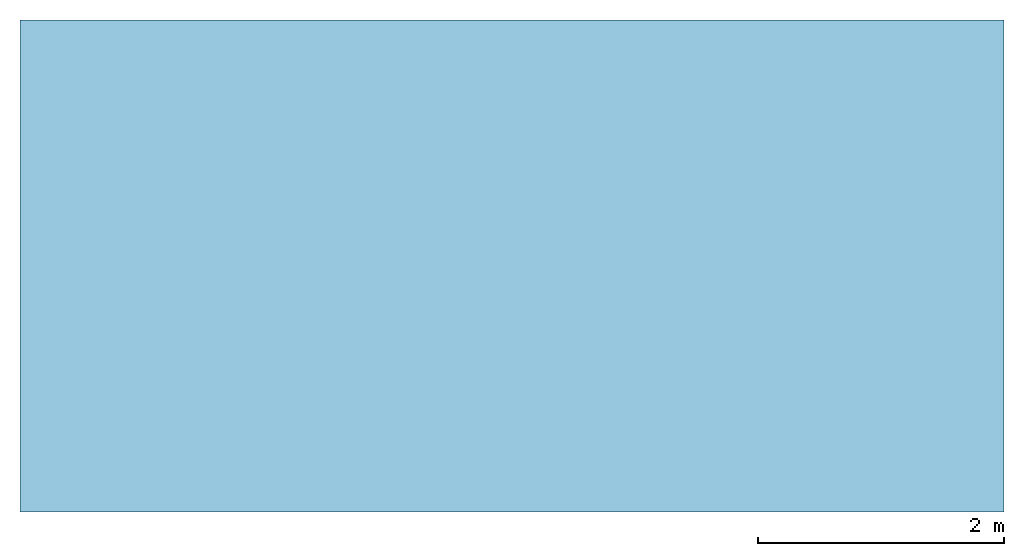
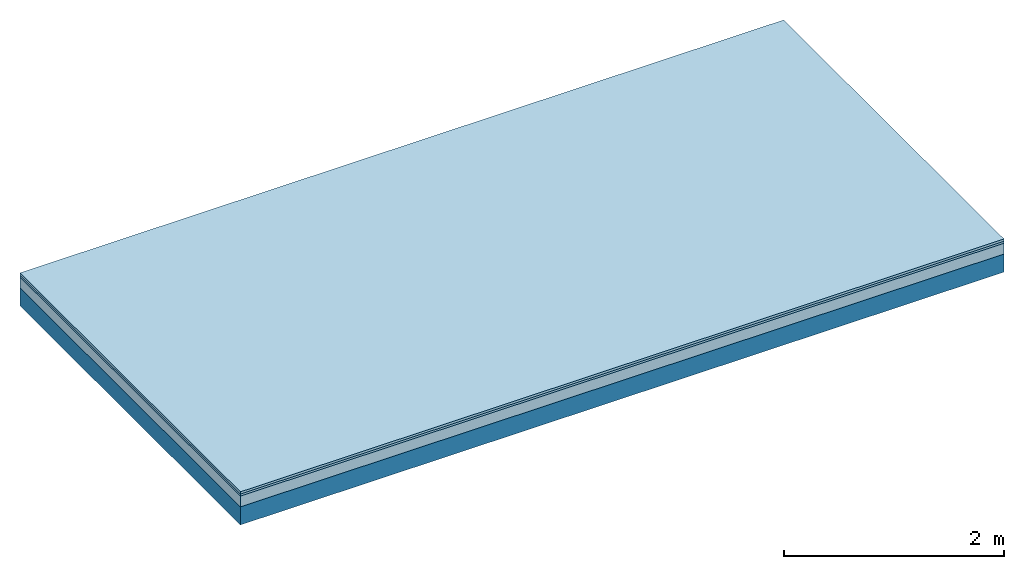
# One storey: 3 plates, 1 member, 1 element without a shape of its own.
"""IFC4 building model written with IfcOpenShell, lengths in metres."""

from ifc_helpers import new_model, si_unit, derived_unit, direction, frame, frame_2d, origin, origin_with_axes, place, context, project, spatial, rectangle, extrude, material, layer, layer_set, type_object, element, aggregate, save


model = new_model("IFC4")

# Units and contexts
plan_context = context("Plan", 3, precision=1e-05, world=origin(), true_north=direction((0.0, 1.0)))
model_context = context("Model", 3, precision=1e-05, world=origin(), true_north=direction((0.0, 1.0)))
ifc_project = project(units=[si_unit("LENGTHUNIT", "METRE"), derived_unit("SOUNDPRESSUREUNIT", [(si_unit("PRESSUREUNIT", "PASCAL", prefix="MICRO"), 0)]), si_unit("ENERGYUNIT", "JOULE", prefix="MEGA"), si_unit("MASSUNIT", "GRAM", prefix="KILO"), derived_unit("THERMALTRANSMITTANCEUNIT", [(si_unit("POWERUNIT", "WATT"), 1), (si_unit("AREAUNIT", "SQUARE_METRE"), -1), (si_unit("THERMODYNAMICTEMPERATUREUNIT", "KELVIN"), -1)]), derived_unit("AREADENSITYUNIT", [(si_unit("MASSUNIT", "GRAM", prefix="KILO"), 1), (si_unit("AREAUNIT", "SQUARE_METRE"), -1)]), derived_unit("USERDEFINED", [(si_unit("ENERGYUNIT", "JOULE", prefix="MEGA"), 1), (si_unit("AREAUNIT", "SQUARE_METRE"), -1)])], contexts=[plan_context, model_context])

# Site, building, storey
site = spatial("IfcSite", under=ifc_project)
building_placement = place(None, origin())
building = spatial("IfcBuilding", under=site, at=building_placement)
storey_placement = place(building_placement, origin())
storey = spatial("IfcBuildingStorey", under=building, at=storey_placement)

# Slab, member, plates
ifc_material_1 = material(Name="Floor heating system Therm38 longitudinal", Category="03.007")
ifc_layer_1 = layer(ifc_material_1, 0.025, Name="On-material")
ifc_material_2 = material(Category="10.009")
ifc_layer_2 = layer(ifc_material_2, 0.022, Name="Impact sound insulation")
ifc_material_3 = material(Category="03.011")
ifc_layer_3 = layer(ifc_material_3, 0.12, Name="on Supporting structure")
ifc_layer_4 = layer(None, 0.2, Name="Supporting structure")
ifc_layer_set = layer_set([ifc_layer_1, ifc_layer_2, ifc_layer_3, ifc_layer_4])
slab_type = type_object("IfcSlabType", Name="A1101", PredefinedType="NOTDEFINED", material=ifc_layer_set)
slab_placement = place(None, frame((0.0, 0.0, 0.0), z_axis=(0.0, 0.0, -1.0), x_axis=(1.0, 0.0, 0.0)))
slab = element("IfcSlab", 1, at=slab_placement, inside=storey, type_object=slab_type, material=ifc_layer_set, Name="Slab #1")
ifc_material_4 = material()
member_placement = place(slab_placement, origin())
member = element("IfcMember", 2, at=member_placement, material=ifc_material_4, Name="Supporting structure", context=plan_context, shape_type="SweptSolid", body=[
    extrude(rectangle(XDim=1.0, YDim=0.2, at=frame_2d((0.5, 0.1), x_axis=(1.0, 0.0))), frame((0.0, 4.0, 0.167), z_axis=(0.0, -1.0, 0.0), x_axis=(1.0, 0.0, 0.0)), (0.0, 0.0, 1.0), 4.0),
    extrude(rectangle(XDim=1.0, YDim=0.2, at=frame_2d((0.5, 0.1), x_axis=(1.0, 0.0))), frame((1.0, 4.0, 0.167), z_axis=(0.0, -1.0, 0.0), x_axis=(1.0, 0.0, 0.0)), (0.0, 0.0, 1.0), 4.0),
    extrude(rectangle(XDim=1.0, YDim=0.2, at=frame_2d((0.5, 0.1), x_axis=(1.0, 0.0))), frame((2.0, 4.0, 0.167), z_axis=(0.0, -1.0, 0.0), x_axis=(1.0, 0.0, 0.0)), (0.0, 0.0, 1.0), 4.0),
    extrude(rectangle(XDim=1.0, YDim=0.2, at=frame_2d((0.5, 0.1), x_axis=(1.0, 0.0))), frame((3.0, 4.0, 0.167), z_axis=(0.0, -1.0, 0.0), x_axis=(1.0, 0.0, 0.0)), (0.0, 0.0, 1.0), 4.0),
    extrude(rectangle(XDim=1.0, YDim=0.2, at=frame_2d((0.5, 0.1), x_axis=(1.0, 0.0))), frame((4.0, 4.0, 0.167), z_axis=(0.0, -1.0, 0.0), x_axis=(1.0, 0.0, 0.0)), (0.0, 0.0, 1.0), 4.0),
    extrude(rectangle(XDim=1.0, YDim=0.2, at=frame_2d((0.5, 0.1), x_axis=(1.0, 0.0))), frame((5.0, 4.0, 0.167), z_axis=(0.0, -1.0, 0.0), x_axis=(1.0, 0.0, 0.0)), (0.0, 0.0, 1.0), 4.0),
    extrude(rectangle(XDim=1.0, YDim=0.2, at=frame_2d((0.5, 0.1), x_axis=(1.0, 0.0))), frame((6.0, 4.0, 0.167), z_axis=(0.0, -1.0, 0.0), x_axis=(1.0, 0.0, 0.0)), (0.0, 0.0, 1.0), 4.0),
    extrude(rectangle(XDim=1.0, YDim=0.2, at=frame_2d((0.5, 0.1), x_axis=(1.0, 0.0))), frame((7.0, 4.0, 0.167), z_axis=(0.0, -1.0, 0.0), x_axis=(1.0, 0.0, 0.0)), (0.0, 0.0, 1.0), 4.0),
])
plate_1_placement = place(slab_placement, origin())
plate_1 = element("IfcPlate", 3, at=plate_1_placement, material=ifc_material_1, Name="On-material", context=plan_context, shape_type="SweptSolid", body=[
    extrude(rectangle(XDim=8.0, YDim=4.0, at=frame_2d((4.0, 2.0), x_axis=(1.0, 0.0))), origin_with_axes(), (0.0, 0.0, 1.0), 0.025),
])
plate_2_placement = place(slab_placement, origin())
plate_2 = element("IfcPlate", 4, at=plate_2_placement, material=ifc_material_2, Name="Impact sound insulation", context=plan_context, shape_type="SweptSolid", body=[
    extrude(rectangle(XDim=8.0, YDim=4.0, at=frame_2d((4.0, 2.0), x_axis=(1.0, 0.0))), frame((0.0, 0.0, 0.025), z_axis=(0.0, 0.0, 1.0), x_axis=(1.0, 0.0, 0.0)), (0.0, 0.0, 1.0), 0.022),
])
plate_3_placement = place(slab_placement, origin())
plate_3 = element("IfcPlate", 5, at=plate_3_placement, material=ifc_material_3, Name="on Supporting structure", context=plan_context, shape_type="SweptSolid", body=[
    extrude(rectangle(XDim=8.0, YDim=4.0, at=frame_2d((4.0, 2.0), x_axis=(1.0, 0.0))), frame((0.0, 0.0, 0.047), z_axis=(0.0, 0.0, 1.0), x_axis=(1.0, 0.0, 0.0)), (0.0, 0.0, 1.0), 0.12),
])
aggregate(slab, [plate_1, plate_2, plate_3, member])

save(model, "model.ifc")
